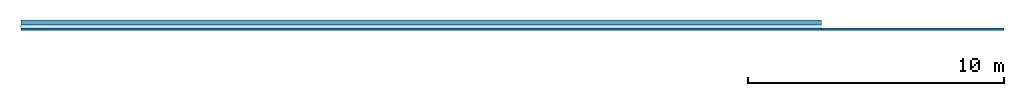
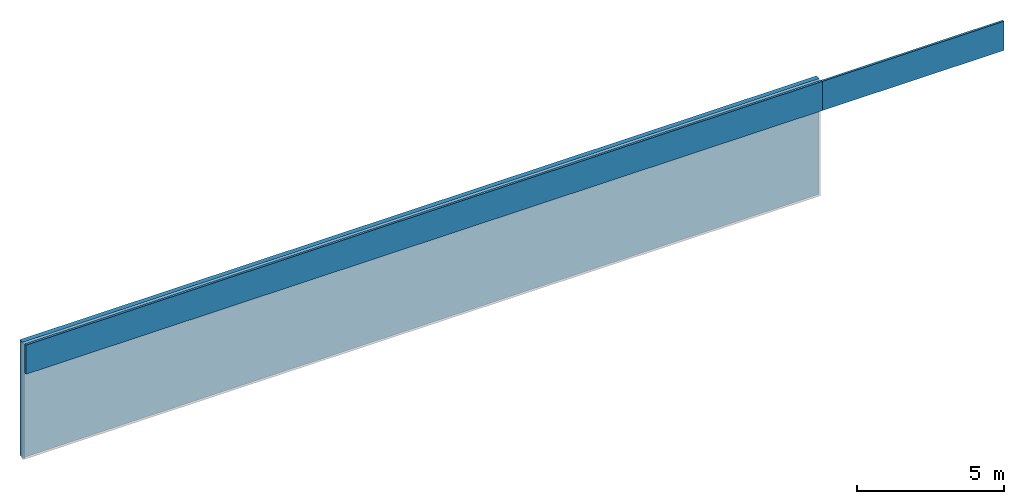
# Not in any storey, part 1 of 2: 3 walls.
"""IFC4X3_ADD2 model written with IfcOpenShell, lengths in millimetres."""

from ifc_helpers import new_model, entity, si_unit, converted_unit, frame, origin_with_axes, origin_2d_with_axis, place, context, subcontext, project, indexed_curve, outline, extrude, material, layer, layer_set, layer_usage, type_object, element, save


model = new_model("IFC4X3_ADD2")

# Units and contexts
model_context = context("Model", 3, precision=1e-05, world=origin_with_axes())
plan_context = context("Plan", 2, precision=1e-05, world=origin_2d_with_axis())
body_context = subcontext(model_context, "Body", "Model", "MODEL_VIEW")
ifc_project = project(units=[converted_unit("PLANEANGLEUNIT", "degree", entity("IfcReal", 0.0174532925199433), si_unit("PLANEANGLEUNIT", "RADIAN"), dimensions=[0, 0, 0, 0, 0, 0, 0]), si_unit("AREAUNIT", "SQUARE_METRE", prefix="MILLI"), si_unit("VOLUMEUNIT", "CUBIC_METRE", prefix="MILLI"), si_unit("LENGTHUNIT", "METRE", prefix="MILLI")], contexts=[model_context, plan_context])

# Walls
ifc_material_1 = material(Name="Concrete Masonry Block", Category="04200 Unit Masonry")
ifc_layer_1 = layer(ifc_material_1, 190.0, Name="Interior Block Wall", Category="Div 04")
ifc_layer_set_1 = layer_set([ifc_layer_1])
ifc_layer_usage_1 = layer_usage(ifc_layer_set_1, "AXIS2", "POSITIVE", 0.0)
wall_type_1 = type_object("IfcWallType", Name="Conc. Block- 190mm", PredefinedType="ELEMENTEDWALL", material=ifc_layer_set_1)
wall_1_placement = place(None, frame((34477.9205322266, -2707.69262313843, 0.0), z_axis=(0.0, 0.0, 1.0), x_axis=(-0.999999999999989, 1.50995802528085e-07, 0.0)))
element("IfcWall", 1, at=wall_1_placement, type_object=wall_type_1, material=ifc_layer_usage_1, Name="Wall", context=body_context, shape_type="SweptSolid", body=[
    extrude(outline(indexed_curve([(0.0, 0.0), (0.0, 190.0), (31278.9270413084, 190.0), (31278.9270413084, 0.0), (0.0, 0.0)], self_intersect=False)), origin_with_axes(), (0.0, 0.0, 1.0), 4800.00019073486),
])
ifc_material_2 = material(Name="Brick", Category="04200 Unit Masonry")
ifc_layer_2 = layer(ifc_material_2, 90.0, Name="Block", Category="Div 04")
ifc_layer_set_2 = layer_set([ifc_layer_2])
ifc_layer_usage_2 = layer_usage(ifc_layer_set_2, "AXIS2", "POSITIVE", 0.0)
wall_type_2 = type_object("IfcWallType", Name="Brick - 90mm", PredefinedType="ELEMENTEDWALL", material=ifc_layer_set_2)
wall_2_placement = place(None, frame((3198.99368286133, -3109.16328430176, 3600.00014305115), z_axis=(0.0, 0.0, 1.0), x_axis=(1.0, 0.0, 0.0)))
element("IfcWall", 2, at=wall_2_placement, type_object=wall_type_2, material=ifc_layer_usage_2, Name="Wall", context=body_context, shape_type="SweptSolid", body=[
    extrude(outline(indexed_curve([(0.0, 0.0), (0.0, 90.0), (31278.927041308, 90.0), (31278.927041308, 0.0), (0.0, 0.0)], self_intersect=False)), origin_with_axes(), (0.0, 0.0, 1.0), 1209.40005779266),
])
ifc_layer_usage_3 = layer_usage(ifc_layer_set_2, "AXIS2", "POSITIVE", 0.0)
wall_3_placement = place(None, frame((34477.9205322266, -3109.16328430176, 3600.00014305115), z_axis=(0.0, 0.0, 1.0), x_axis=(1.0, 0.0, 0.0)))
element("IfcWall", 3, at=wall_3_placement, type_object=wall_type_2, material=ifc_layer_usage_3, Name="Wall", context=body_context, shape_type="SweptSolid", body=[
    extrude(outline(indexed_curve([(0.0, 0.0), (0.0, 90.0), (7136.91705303996, 90.0), (7136.91705303996, 0.0), (0.0, 0.0)], self_intersect=False)), origin_with_axes(), (0.0, 0.0, 1.0), 1209.40005779266),
])

save(model, "model.ifc")
